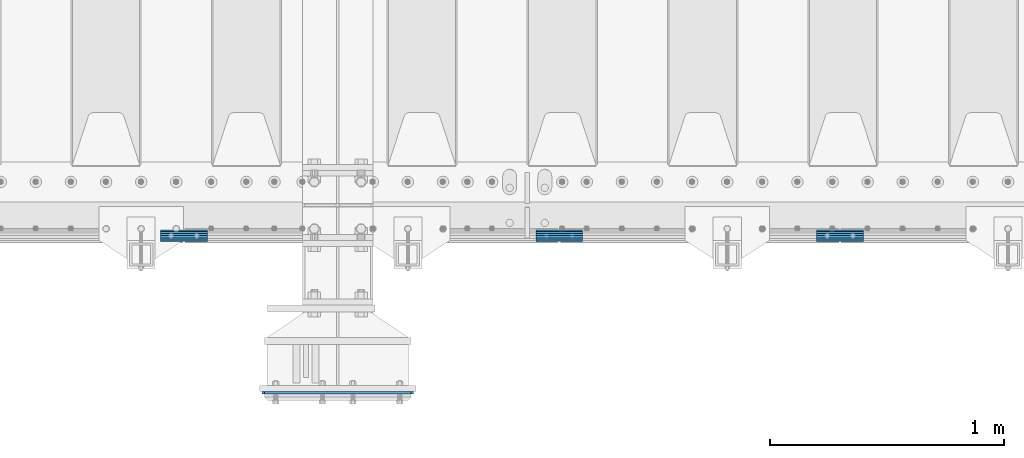
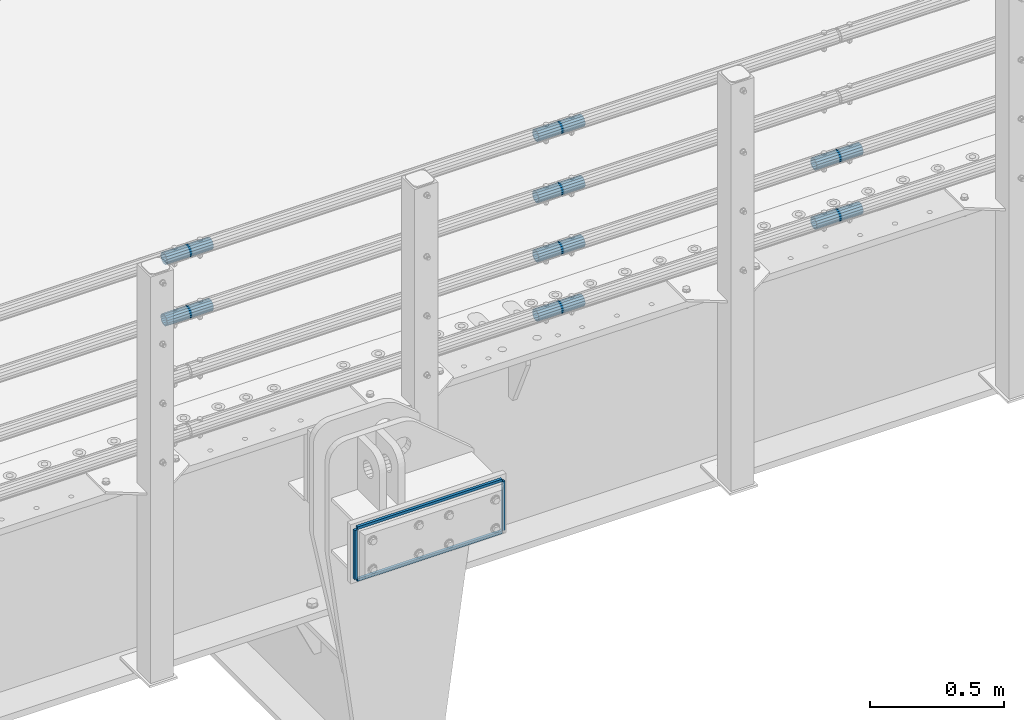
# One storey, part 126 of 219: 12 beams.
"""IFC2X3 building model written with IfcOpenShell, lengths in millimetres."""

from ifc_helpers import new_model, si_unit, frame, origin_with_axes, place, context, subcontext, project, spatial, faceted_brep, material, type_object, element, save


model = new_model("IFC2X3")

# Units and contexts
model_context = context("Model", 3, precision=1e-05, world=origin_with_axes())
body_context = subcontext(model_context, "Body", "Model", "MODEL_VIEW")
ifc_project = project(units=[si_unit("LENGTHUNIT", "METRE", prefix="MILLI"), si_unit("AREAUNIT", "SQUARE_METRE"), si_unit("VOLUMEUNIT", "CUBIC_METRE"), si_unit("MASSUNIT", "GRAM", prefix="KILO"), si_unit("TIMEUNIT", "SECOND"), si_unit("PLANEANGLEUNIT", "RADIAN"), si_unit("SOLIDANGLEUNIT", "STERADIAN"), si_unit("THERMODYNAMICTEMPERATUREUNIT", "DEGREE_CELSIUS"), si_unit("LUMINOUSINTENSITYUNIT", "LUMEN")], contexts=[model_context])

# Site, building, storey
site_placement = place(None, origin_with_axes())
site = spatial("IfcSite", under=ifc_project, at=site_placement, CompositionType="ELEMENT")
building_placement = place(site_placement, origin_with_axes())
building = spatial("IfcBuilding", under=site, at=building_placement, Name="Standard", CompositionType="ELEMENT")
storey_placement = place(building_placement, origin_with_axes())
storey = spatial("IfcBuildingStorey", under=building, at=storey_placement, Name="Undefined", CompositionType="ELEMENT", Elevation=0.0)

# Beams
ifc_material_1 = material(Name="STEEL/S355N")
beam_type_1 = type_object("IfcBeamType", PredefinedType="NOTDEFINED")
for number, where, z_axis, x_axis in (
    (1, (10071.5000000202, 23199.000000015, -12.5000182061987), (-1.0, 0.0, 0.0), (0.0, 0.0, -1.0)),
    (2, (10708.5000000219, 23199.0000000148, -12.5000182061987), (-1.0, 0.0, 0.0), (0.0, 0.0, -1.0)),
):
    element("IfcBeam", number, at=place(storey_placement, frame(where, z_axis=z_axis, x_axis=x_axis)), inside=storey, type_object=beam_type_1, material=ifc_material_1, context=body_context, shape_type="Brep", body=[
        faceted_brep([(0.0, 6.0, -6.0), (0.0, 6.0, 6.0), (225.0, 6.0, 6.0), (225.0, 6.0, -6.0), (0.0, -6.0, 6.0), (225.0, -6.0, 6.0), (0.0, -6.0, -6.0), (225.0, -6.0, -6.0)], [[[0, 1, 2, 3]], [[1, 4, 5, 2]], [[4, 6, 7, 5]], [[6, 0, 3, 7]], [[5, 7, 3, 2]], [[6, 4, 1, 0]]]),
    ])
for number, where, z_axis, x_axis in (
    (3, (10077.5000000202, 23199.000000015, -6.50001820619866), (0.0, 0.0, -1.0), (1.0, 0.0, 0.0)),
    (4, (10077.5000000202, 23199.000000015, -243.500018206199), (0.0, 0.0, -1.0), (1.0, 0.0, 0.0)),
):
    element("IfcBeam", number, at=place(storey_placement, frame(where, z_axis=z_axis, x_axis=x_axis)), inside=storey, type_object=beam_type_1, material=ifc_material_1, context=body_context, shape_type="Brep", body=[
        faceted_brep([(0.0, 6.0, -6.0), (0.0, 6.0, 6.0), (625.000000001684, 6.0, 6.0), (625.000000001684, 6.0, -6.0), (0.0, -6.0, 6.0), (625.000000001684, -6.0, 6.0), (0.0, -6.0, -6.0), (625.000000001684, -6.0, -6.0)], [[[0, 1, 2, 3]], [[1, 4, 5, 2]], [[4, 6, 7, 5]], [[6, 0, 3, 7]], [[5, 7, 3, 2]], [[6, 4, 1, 0]]]),
    ])
ifc_material_2 = material()
beam_type_2 = type_object("IfcBeamType", PredefinedType="NOTDEFINED")
beam_1_placement = place(storey_placement, frame((11236.9975029999, 23870.1500000004, 149.849999999747), z_axis=(0.0, 0.0, 1.0), x_axis=(1.0, 0.0, 0.0)))
element("IfcBeam", 5, at=beam_1_placement, inside=storey, type_object=beam_type_2, material=ifc_material_2, context=body_context, shape_type="Brep", body=[
    faceted_brep([(0.0, -21.9000000000015, 0.0), (0.0, -20.232961761998, 8.38076716879547), (200.0, -20.232961761998, 8.38076716879547), (200.0, -21.9000000000015, 0.0), (0.0, -15.4856385079838, 15.4856385079854), (200.0, -15.4856385079838, 15.4856385079854), (0.0, -8.38076716879732, 20.2329617619972), (200.0, -8.38076716879732, 20.2329617619972), (0.0, 0.0, 21.9), (200.0, 0.0, 21.9), (0.0, 8.38076716879732, 20.2329617619972), (200.0, 8.38076716879732, 20.2329617619972), (0.0, 15.4856385079838, 15.4856385079854), (200.0, 15.4856385079838, 15.4856385079854), (0.0, 20.232961761998, 8.38076716879547), (200.0, 20.232961761998, 8.38076716879547), (0.0, 21.9000000000015, 0.0), (200.0, 21.9000000000015, 0.0), (0.0, 20.232961761998, -8.38076716879547), (200.0, 20.232961761998, -8.38076716879547), (0.0, 15.4856385079838, -15.4856385079854), (200.0, 15.4856385079838, -15.4856385079854), (0.0, 8.38076716879732, -20.2329617619972), (200.0, 8.38076716879732, -20.2329617619972), (0.0, 0.0, -21.9), (200.0, 0.0, -21.9), (0.0, -8.38076716879732, -20.2329617619972), (200.0, -8.38076716879732, -20.2329617619972), (0.0, -15.4856385079838, -15.4856385079854), (200.0, -15.4856385079838, -15.4856385079854), (0.0, -20.232961761998, -8.38076716879547), (200.0, -20.232961761998, -8.38076716879547), (0.0, -25.5, 0.0), (0.0, -23.5589280790373, -9.7584275253098), (200.0, -23.5589280790373, -9.7584275253098), (200.0, -25.5, 0.0), (0.0, -18.0312229202536, -18.031222920257), (200.0, -18.0312229202536, -18.031222920257), (0.0, -9.75842752531025, -23.5589280790378), (200.0, -9.75842752531025, -23.5589280790378), (0.0, 0.0, -25.5), (200.0, 0.0, -25.5), (0.0, 9.75842752531025, -23.5589280790378), (200.0, 9.75842752531025, -23.5589280790378), (0.0, 18.0312229202536, -18.031222920257), (200.0, 18.0312229202536, -18.031222920257), (0.0, 23.5589280790373, -9.7584275253098), (200.0, 23.5589280790373, -9.7584275253098), (0.0, 25.5, 0.0), (200.0, 25.5, 0.0), (0.0, 23.5589280790373, 9.7584275253098), (200.0, 23.5589280790373, 9.7584275253098), (0.0, 18.0312229202536, 18.031222920257), (200.0, 18.0312229202536, 18.031222920257), (0.0, 9.75842752531025, 23.5589280790378), (200.0, 9.75842752531025, 23.5589280790378), (0.0, 0.0, 25.5), (200.0, 0.0, 25.5), (0.0, -9.75842752531025, 23.5589280790378), (200.0, -9.75842752531025, 23.5589280790378), (0.0, -18.0312229202536, 18.031222920257), (200.0, -18.0312229202536, 18.031222920257), (0.0, -23.5589280790373, 9.7584275253098), (200.0, -23.5589280790373, 9.7584275253098)], [[[0, 1, 2, 3]], [[1, 4, 5, 2]], [[4, 6, 7, 5]], [[6, 8, 9, 7]], [[8, 10, 11, 9]], [[10, 12, 13, 11]], [[12, 14, 15, 13]], [[14, 16, 17, 15]], [[16, 18, 19, 17]], [[18, 20, 21, 19]], [[20, 22, 23, 21]], [[22, 24, 25, 23]], [[24, 26, 27, 25]], [[26, 28, 29, 27]], [[28, 30, 31, 29]], [[30, 0, 3, 31]], [[32, 33, 34, 35]], [[33, 36, 37, 34]], [[36, 38, 39, 37]], [[38, 40, 41, 39]], [[40, 42, 43, 41]], [[42, 44, 45, 43]], [[44, 46, 47, 45]], [[46, 48, 49, 47]], [[48, 50, 51, 49]], [[50, 52, 53, 51]], [[52, 54, 55, 53]], [[54, 56, 57, 55]], [[56, 58, 59, 57]], [[58, 60, 61, 59]], [[60, 62, 63, 61]], [[62, 32, 35, 63]], [[37, 39, 41, 43, 45, 47, 49, 51, 53, 55, 57, 59, 61, 63, 35, 34], [5, 7, 9, 11, 13, 15, 17, 19, 21, 23, 25, 27, 29, 31, 3, 2]], [[62, 60, 58, 56, 54, 52, 50, 48, 46, 44, 42, 40, 38, 36, 33, 32], [30, 28, 26, 24, 22, 20, 18, 16, 14, 12, 10, 8, 6, 4, 1, 0]]]),
])
beam_2_placement = place(storey_placement, frame((11236.9975029999, 23870.1500000004, 420.149999999747), z_axis=(0.0, 0.0, 1.0), x_axis=(1.0, 0.0, 0.0)))
element("IfcBeam", 6, at=beam_2_placement, inside=storey, type_object=beam_type_2, material=ifc_material_2, context=body_context, shape_type="Brep", body=[
    faceted_brep([(0.0, -21.9000000000015, 0.0), (0.0, -20.232961761998, 8.38076716879547), (200.0, -20.232961761998, 8.38076716879547), (200.0, -21.9000000000015, 0.0), (0.0, -15.4856385079838, 15.4856385079854), (200.0, -15.4856385079838, 15.4856385079854), (0.0, -8.38076716879732, 20.2329617619972), (200.0, -8.38076716879732, 20.2329617619972), (0.0, 0.0, 21.9), (200.0, 0.0, 21.9), (0.0, 8.38076716879732, 20.2329617619972), (200.0, 8.38076716879732, 20.2329617619972), (0.0, 15.4856385079838, 15.4856385079854), (200.0, 15.4856385079838, 15.4856385079854), (0.0, 20.232961761998, 8.38076716879547), (200.0, 20.232961761998, 8.38076716879547), (0.0, 21.9000000000015, 0.0), (200.0, 21.9000000000015, 0.0), (0.0, 20.232961761998, -8.38076716879547), (200.0, 20.232961761998, -8.38076716879547), (0.0, 15.4856385079838, -15.4856385079854), (200.0, 15.4856385079838, -15.4856385079854), (0.0, 8.38076716879732, -20.2329617619972), (200.0, 8.38076716879732, -20.2329617619972), (0.0, 0.0, -21.9), (200.0, 0.0, -21.9), (0.0, -8.38076716879732, -20.2329617619972), (200.0, -8.38076716879732, -20.2329617619972), (0.0, -15.4856385079838, -15.4856385079854), (200.0, -15.4856385079838, -15.4856385079854), (0.0, -20.232961761998, -8.38076716879547), (200.0, -20.232961761998, -8.38076716879547), (0.0, -25.5, 0.0), (0.0, -23.5589280790373, -9.7584275253098), (200.0, -23.5589280790373, -9.7584275253098), (200.0, -25.5, 0.0), (0.0, -18.0312229202536, -18.031222920257), (200.0, -18.0312229202536, -18.031222920257), (0.0, -9.75842752531025, -23.5589280790378), (200.0, -9.75842752531025, -23.5589280790378), (0.0, 0.0, -25.5), (200.0, 0.0, -25.5), (0.0, 9.75842752531025, -23.5589280790378), (200.0, 9.75842752531025, -23.5589280790378), (0.0, 18.0312229202536, -18.031222920257), (200.0, 18.0312229202536, -18.031222920257), (0.0, 23.5589280790373, -9.7584275253098), (200.0, 23.5589280790373, -9.7584275253098), (0.0, 25.5, 0.0), (200.0, 25.5, 0.0), (0.0, 23.5589280790373, 9.7584275253098), (200.0, 23.5589280790373, 9.7584275253098), (0.0, 18.0312229202536, 18.031222920257), (200.0, 18.0312229202536, 18.031222920257), (0.0, 9.75842752531025, 23.5589280790378), (200.0, 9.75842752531025, 23.5589280790378), (0.0, 0.0, 25.5), (200.0, 0.0, 25.5), (0.0, -9.75842752531025, 23.5589280790378), (200.0, -9.75842752531025, 23.5589280790378), (0.0, -18.0312229202536, 18.031222920257), (200.0, -18.0312229202536, 18.031222920257), (0.0, -23.5589280790373, 9.7584275253098), (200.0, -23.5589280790373, 9.7584275253098)], [[[0, 1, 2, 3]], [[1, 4, 5, 2]], [[4, 6, 7, 5]], [[6, 8, 9, 7]], [[8, 10, 11, 9]], [[10, 12, 13, 11]], [[12, 14, 15, 13]], [[14, 16, 17, 15]], [[16, 18, 19, 17]], [[18, 20, 21, 19]], [[20, 22, 23, 21]], [[22, 24, 25, 23]], [[24, 26, 27, 25]], [[26, 28, 29, 27]], [[28, 30, 31, 29]], [[30, 0, 3, 31]], [[32, 33, 34, 35]], [[33, 36, 37, 34]], [[36, 38, 39, 37]], [[38, 40, 41, 39]], [[40, 42, 43, 41]], [[42, 44, 45, 43]], [[44, 46, 47, 45]], [[46, 48, 49, 47]], [[48, 50, 51, 49]], [[50, 52, 53, 51]], [[52, 54, 55, 53]], [[54, 56, 57, 55]], [[56, 58, 59, 57]], [[58, 60, 61, 59]], [[60, 62, 63, 61]], [[62, 32, 35, 63]], [[37, 39, 41, 43, 45, 47, 49, 51, 53, 55, 57, 59, 61, 63, 35, 34], [5, 7, 9, 11, 13, 15, 17, 19, 21, 23, 25, 27, 29, 31, 3, 2]], [[62, 60, 58, 56, 54, 52, 50, 48, 46, 44, 42, 40, 38, 36, 33, 32], [30, 28, 26, 24, 22, 20, 18, 16, 14, 12, 10, 8, 6, 4, 1, 0]]]),
])
beam_3_placement = place(storey_placement, frame((9632.99750299995, 23870.1500000004, 969.849999999747), z_axis=(0.0, 0.0, 1.0), x_axis=(1.0, 0.0, 0.0)))
element("IfcBeam", 7, at=beam_3_placement, inside=storey, type_object=beam_type_2, material=ifc_material_2, context=body_context, shape_type="Brep", body=[
    faceted_brep([(0.0, -21.9000000000015, 0.0), (0.0, -20.232961761998, 8.38076716879547), (200.0, -20.232961761998, 8.38076716879547), (200.0, -21.9000000000015, 0.0), (0.0, -15.4856385079838, 15.4856385079854), (200.0, -15.4856385079838, 15.4856385079854), (0.0, -8.38076716879732, 20.2329617619972), (200.0, -8.38076716879732, 20.2329617619972), (0.0, 0.0, 21.9), (200.0, 0.0, 21.9), (0.0, 8.38076716879732, 20.2329617619972), (200.0, 8.38076716879732, 20.2329617619972), (0.0, 15.4856385079838, 15.4856385079854), (200.0, 15.4856385079838, 15.4856385079854), (0.0, 20.232961761998, 8.38076716879547), (200.0, 20.232961761998, 8.38076716879547), (0.0, 21.9000000000015, 0.0), (200.0, 21.9000000000015, 0.0), (0.0, 20.232961761998, -8.38076716879547), (200.0, 20.232961761998, -8.38076716879547), (0.0, 15.4856385079838, -15.4856385079854), (200.0, 15.4856385079838, -15.4856385079854), (0.0, 8.38076716879732, -20.2329617619972), (200.0, 8.38076716879732, -20.2329617619972), (0.0, 0.0, -21.9), (200.0, 0.0, -21.9), (0.0, -8.38076716879732, -20.2329617619972), (200.0, -8.38076716879732, -20.2329617619972), (0.0, -15.4856385079838, -15.4856385079854), (200.0, -15.4856385079838, -15.4856385079854), (0.0, -20.232961761998, -8.38076716879547), (200.0, -20.232961761998, -8.38076716879547), (0.0, -25.5, 0.0), (0.0, -23.5589280790373, -9.7584275253098), (200.0, -23.5589280790373, -9.7584275253098), (200.0, -25.5, 0.0), (0.0, -18.0312229202536, -18.031222920257), (200.0, -18.0312229202536, -18.031222920257), (0.0, -9.75842752531025, -23.5589280790378), (200.0, -9.75842752531025, -23.5589280790378), (0.0, 0.0, -25.5), (200.0, 0.0, -25.5), (0.0, 9.75842752531025, -23.5589280790378), (200.0, 9.75842752531025, -23.5589280790378), (0.0, 18.0312229202536, -18.031222920257), (200.0, 18.0312229202536, -18.031222920257), (0.0, 23.5589280790373, -9.7584275253098), (200.0, 23.5589280790373, -9.7584275253098), (0.0, 25.5, 0.0), (200.0, 25.5, 0.0), (0.0, 23.5589280790373, 9.7584275253098), (200.0, 23.5589280790373, 9.7584275253098), (0.0, 18.0312229202536, 18.031222920257), (200.0, 18.0312229202536, 18.031222920257), (0.0, 9.75842752531025, 23.5589280790378), (200.0, 9.75842752531025, 23.5589280790378), (0.0, 0.0, 25.5), (200.0, 0.0, 25.5), (0.0, -9.75842752531025, 23.5589280790378), (200.0, -9.75842752531025, 23.5589280790378), (0.0, -18.0312229202536, 18.031222920257), (200.0, -18.0312229202536, 18.031222920257), (0.0, -23.5589280790373, 9.7584275253098), (200.0, -23.5589280790373, 9.7584275253098)], [[[0, 1, 2, 3]], [[1, 4, 5, 2]], [[4, 6, 7, 5]], [[6, 8, 9, 7]], [[8, 10, 11, 9]], [[10, 12, 13, 11]], [[12, 14, 15, 13]], [[14, 16, 17, 15]], [[16, 18, 19, 17]], [[18, 20, 21, 19]], [[20, 22, 23, 21]], [[22, 24, 25, 23]], [[24, 26, 27, 25]], [[26, 28, 29, 27]], [[28, 30, 31, 29]], [[30, 0, 3, 31]], [[32, 33, 34, 35]], [[33, 36, 37, 34]], [[36, 38, 39, 37]], [[38, 40, 41, 39]], [[40, 42, 43, 41]], [[42, 44, 45, 43]], [[44, 46, 47, 45]], [[46, 48, 49, 47]], [[48, 50, 51, 49]], [[50, 52, 53, 51]], [[52, 54, 55, 53]], [[54, 56, 57, 55]], [[56, 58, 59, 57]], [[58, 60, 61, 59]], [[60, 62, 63, 61]], [[62, 32, 35, 63]], [[37, 39, 41, 43, 45, 47, 49, 51, 53, 55, 57, 59, 61, 63, 35, 34], [5, 7, 9, 11, 13, 15, 17, 19, 21, 23, 25, 27, 29, 31, 3, 2]], [[62, 60, 58, 56, 54, 52, 50, 48, 46, 44, 42, 40, 38, 36, 33, 32], [30, 28, 26, 24, 22, 20, 18, 16, 14, 12, 10, 8, 6, 4, 1, 0]]]),
])
beam_4_placement = place(storey_placement, frame((11236.9975029999, 23870.1500000004, 969.849999999747), z_axis=(0.0, 0.0, 1.0), x_axis=(1.0, 0.0, 0.0)))
element("IfcBeam", 8, at=beam_4_placement, inside=storey, type_object=beam_type_2, material=ifc_material_2, context=body_context, shape_type="Brep", body=[
    faceted_brep([(0.0, -21.9000000000015, 0.0), (0.0, -20.232961761998, 8.38076716879547), (200.0, -20.232961761998, 8.38076716879547), (200.0, -21.9000000000015, 0.0), (0.0, -15.4856385079838, 15.4856385079854), (200.0, -15.4856385079838, 15.4856385079854), (0.0, -8.38076716879732, 20.2329617619972), (200.0, -8.38076716879732, 20.2329617619972), (0.0, 0.0, 21.9), (200.0, 0.0, 21.9), (0.0, 8.38076716879732, 20.2329617619972), (200.0, 8.38076716879732, 20.2329617619972), (0.0, 15.4856385079838, 15.4856385079854), (200.0, 15.4856385079838, 15.4856385079854), (0.0, 20.232961761998, 8.38076716879547), (200.0, 20.232961761998, 8.38076716879547), (0.0, 21.9000000000015, 0.0), (200.0, 21.9000000000015, 0.0), (0.0, 20.232961761998, -8.38076716879547), (200.0, 20.232961761998, -8.38076716879547), (0.0, 15.4856385079838, -15.4856385079854), (200.0, 15.4856385079838, -15.4856385079854), (0.0, 8.38076716879732, -20.2329617619972), (200.0, 8.38076716879732, -20.2329617619972), (0.0, 0.0, -21.9), (200.0, 0.0, -21.9), (0.0, -8.38076716879732, -20.2329617619972), (200.0, -8.38076716879732, -20.2329617619972), (0.0, -15.4856385079838, -15.4856385079854), (200.0, -15.4856385079838, -15.4856385079854), (0.0, -20.232961761998, -8.38076716879547), (200.0, -20.232961761998, -8.38076716879547), (0.0, -25.5, 0.0), (0.0, -23.5589280790373, -9.7584275253098), (200.0, -23.5589280790373, -9.7584275253098), (200.0, -25.5, 0.0), (0.0, -18.0312229202536, -18.031222920257), (200.0, -18.0312229202536, -18.031222920257), (0.0, -9.75842752531025, -23.5589280790378), (200.0, -9.75842752531025, -23.5589280790378), (0.0, 0.0, -25.5), (200.0, 0.0, -25.5), (0.0, 9.75842752531025, -23.5589280790378), (200.0, 9.75842752531025, -23.5589280790378), (0.0, 18.0312229202536, -18.031222920257), (200.0, 18.0312229202536, -18.031222920257), (0.0, 23.5589280790373, -9.7584275253098), (200.0, 23.5589280790373, -9.7584275253098), (0.0, 25.5, 0.0), (200.0, 25.5, 0.0), (0.0, 23.5589280790373, 9.7584275253098), (200.0, 23.5589280790373, 9.7584275253098), (0.0, 18.0312229202536, 18.031222920257), (200.0, 18.0312229202536, 18.031222920257), (0.0, 9.75842752531025, 23.5589280790378), (200.0, 9.75842752531025, 23.5589280790378), (0.0, 0.0, 25.5), (200.0, 0.0, 25.5), (0.0, -9.75842752531025, 23.5589280790378), (200.0, -9.75842752531025, 23.5589280790378), (0.0, -18.0312229202536, 18.031222920257), (200.0, -18.0312229202536, 18.031222920257), (0.0, -23.5589280790373, 9.7584275253098), (200.0, -23.5589280790373, 9.7584275253098)], [[[0, 1, 2, 3]], [[1, 4, 5, 2]], [[4, 6, 7, 5]], [[6, 8, 9, 7]], [[8, 10, 11, 9]], [[10, 12, 13, 11]], [[12, 14, 15, 13]], [[14, 16, 17, 15]], [[16, 18, 19, 17]], [[18, 20, 21, 19]], [[20, 22, 23, 21]], [[22, 24, 25, 23]], [[24, 26, 27, 25]], [[26, 28, 29, 27]], [[28, 30, 31, 29]], [[30, 0, 3, 31]], [[32, 33, 34, 35]], [[33, 36, 37, 34]], [[36, 38, 39, 37]], [[38, 40, 41, 39]], [[40, 42, 43, 41]], [[42, 44, 45, 43]], [[44, 46, 47, 45]], [[46, 48, 49, 47]], [[48, 50, 51, 49]], [[50, 52, 53, 51]], [[52, 54, 55, 53]], [[54, 56, 57, 55]], [[56, 58, 59, 57]], [[58, 60, 61, 59]], [[60, 62, 63, 61]], [[62, 32, 35, 63]], [[37, 39, 41, 43, 45, 47, 49, 51, 53, 55, 57, 59, 61, 63, 35, 34], [5, 7, 9, 11, 13, 15, 17, 19, 21, 23, 25, 27, 29, 31, 3, 2]], [[62, 60, 58, 56, 54, 52, 50, 48, 46, 44, 42, 40, 38, 36, 33, 32], [30, 28, 26, 24, 22, 20, 18, 16, 14, 12, 10, 8, 6, 4, 1, 0]]]),
])
beam_5_placement = place(storey_placement, frame((12436.9975029999, 23870.1500000004, 419.849999999747), z_axis=(0.0, 0.0, 1.0), x_axis=(1.0, 0.0, 0.0)))
element("IfcBeam", 9, at=beam_5_placement, inside=storey, type_object=beam_type_2, material=ifc_material_2, context=body_context, shape_type="Brep", body=[
    faceted_brep([(0.0, -21.9000000000015, 0.0), (0.0, -20.232961761998, 8.38076716879547), (200.0, -20.232961761998, 8.38076716879547), (200.0, -21.9000000000015, 0.0), (0.0, -15.4856385079838, 15.4856385079854), (200.0, -15.4856385079838, 15.4856385079854), (0.0, -8.38076716879732, 20.2329617619972), (200.0, -8.38076716879732, 20.2329617619972), (0.0, 0.0, 21.9), (200.0, 0.0, 21.9), (0.0, 8.38076716879732, 20.2329617619972), (200.0, 8.38076716879732, 20.2329617619972), (0.0, 15.4856385079838, 15.4856385079854), (200.0, 15.4856385079838, 15.4856385079854), (0.0, 20.232961761998, 8.38076716879547), (200.0, 20.232961761998, 8.38076716879547), (0.0, 21.9000000000015, 0.0), (200.0, 21.9000000000015, 0.0), (0.0, 20.232961761998, -8.38076716879547), (200.0, 20.232961761998, -8.38076716879547), (0.0, 15.4856385079838, -15.4856385079854), (200.0, 15.4856385079838, -15.4856385079854), (0.0, 8.38076716879732, -20.2329617619972), (200.0, 8.38076716879732, -20.2329617619972), (0.0, 0.0, -21.9), (200.0, 0.0, -21.9), (0.0, -8.38076716879732, -20.2329617619972), (200.0, -8.38076716879732, -20.2329617619972), (0.0, -15.4856385079838, -15.4856385079854), (200.0, -15.4856385079838, -15.4856385079854), (0.0, -20.232961761998, -8.38076716879547), (200.0, -20.232961761998, -8.38076716879547), (0.0, -25.5, 0.0), (0.0, -23.5589280790373, -9.7584275253098), (200.0, -23.5589280790373, -9.7584275253098), (200.0, -25.5, 0.0), (0.0, -18.0312229202536, -18.031222920257), (200.0, -18.0312229202536, -18.031222920257), (0.0, -9.75842752531025, -23.5589280790378), (200.0, -9.75842752531025, -23.5589280790378), (0.0, 0.0, -25.5), (200.0, 0.0, -25.5), (0.0, 9.75842752531025, -23.5589280790378), (200.0, 9.75842752531025, -23.5589280790378), (0.0, 18.0312229202536, -18.031222920257), (200.0, 18.0312229202536, -18.031222920257), (0.0, 23.5589280790373, -9.7584275253098), (200.0, 23.5589280790373, -9.7584275253098), (0.0, 25.5, 0.0), (200.0, 25.5, 0.0), (0.0, 23.5589280790373, 9.7584275253098), (200.0, 23.5589280790373, 9.7584275253098), (0.0, 18.0312229202536, 18.031222920257), (200.0, 18.0312229202536, 18.031222920257), (0.0, 9.75842752531025, 23.5589280790378), (200.0, 9.75842752531025, 23.5589280790378), (0.0, 0.0, 25.5), (200.0, 0.0, 25.5), (0.0, -9.75842752531025, 23.5589280790378), (200.0, -9.75842752531025, 23.5589280790378), (0.0, -18.0312229202536, 18.031222920257), (200.0, -18.0312229202536, 18.031222920257), (0.0, -23.5589280790373, 9.7584275253098), (200.0, -23.5589280790373, 9.7584275253098)], [[[0, 1, 2, 3]], [[1, 4, 5, 2]], [[4, 6, 7, 5]], [[6, 8, 9, 7]], [[8, 10, 11, 9]], [[10, 12, 13, 11]], [[12, 14, 15, 13]], [[14, 16, 17, 15]], [[16, 18, 19, 17]], [[18, 20, 21, 19]], [[20, 22, 23, 21]], [[22, 24, 25, 23]], [[24, 26, 27, 25]], [[26, 28, 29, 27]], [[28, 30, 31, 29]], [[30, 0, 3, 31]], [[32, 33, 34, 35]], [[33, 36, 37, 34]], [[36, 38, 39, 37]], [[38, 40, 41, 39]], [[40, 42, 43, 41]], [[42, 44, 45, 43]], [[44, 46, 47, 45]], [[46, 48, 49, 47]], [[48, 50, 51, 49]], [[50, 52, 53, 51]], [[52, 54, 55, 53]], [[54, 56, 57, 55]], [[56, 58, 59, 57]], [[58, 60, 61, 59]], [[60, 62, 63, 61]], [[62, 32, 35, 63]], [[37, 39, 41, 43, 45, 47, 49, 51, 53, 55, 57, 59, 61, 63, 35, 34], [5, 7, 9, 11, 13, 15, 17, 19, 21, 23, 25, 27, 29, 31, 3, 2]], [[62, 60, 58, 56, 54, 52, 50, 48, 46, 44, 42, 40, 38, 36, 33, 32], [30, 28, 26, 24, 22, 20, 18, 16, 14, 12, 10, 8, 6, 4, 1, 0]]]),
])
beam_6_placement = place(storey_placement, frame((12436.9975029999, 23870.1500000004, 149.849999999747), z_axis=(0.0, 0.0, 1.0), x_axis=(1.0, 0.0, 0.0)))
element("IfcBeam", 10, at=beam_6_placement, inside=storey, type_object=beam_type_2, material=ifc_material_2, context=body_context, shape_type="Brep", body=[
    faceted_brep([(0.0, -21.9000000000015, 0.0), (0.0, -20.232961761998, 8.38076716879547), (200.0, -20.232961761998, 8.38076716879547), (200.0, -21.9000000000015, 0.0), (0.0, -15.4856385079838, 15.4856385079854), (200.0, -15.4856385079838, 15.4856385079854), (0.0, -8.38076716879732, 20.2329617619972), (200.0, -8.38076716879732, 20.2329617619972), (0.0, 0.0, 21.9), (200.0, 0.0, 21.9), (0.0, 8.38076716879732, 20.2329617619972), (200.0, 8.38076716879732, 20.2329617619972), (0.0, 15.4856385079838, 15.4856385079854), (200.0, 15.4856385079838, 15.4856385079854), (0.0, 20.232961761998, 8.38076716879547), (200.0, 20.232961761998, 8.38076716879547), (0.0, 21.9000000000015, 0.0), (200.0, 21.9000000000015, 0.0), (0.0, 20.232961761998, -8.38076716879547), (200.0, 20.232961761998, -8.38076716879547), (0.0, 15.4856385079838, -15.4856385079854), (200.0, 15.4856385079838, -15.4856385079854), (0.0, 8.38076716879732, -20.2329617619972), (200.0, 8.38076716879732, -20.2329617619972), (0.0, 0.0, -21.9), (200.0, 0.0, -21.9), (0.0, -8.38076716879732, -20.2329617619972), (200.0, -8.38076716879732, -20.2329617619972), (0.0, -15.4856385079838, -15.4856385079854), (200.0, -15.4856385079838, -15.4856385079854), (0.0, -20.232961761998, -8.38076716879547), (200.0, -20.232961761998, -8.38076716879547), (0.0, -25.5, 0.0), (0.0, -23.5589280790373, -9.7584275253098), (200.0, -23.5589280790373, -9.7584275253098), (200.0, -25.5, 0.0), (0.0, -18.0312229202536, -18.031222920257), (200.0, -18.0312229202536, -18.031222920257), (0.0, -9.75842752531025, -23.5589280790378), (200.0, -9.75842752531025, -23.5589280790378), (0.0, 0.0, -25.5), (200.0, 0.0, -25.5), (0.0, 9.75842752531025, -23.5589280790378), (200.0, 9.75842752531025, -23.5589280790378), (0.0, 18.0312229202536, -18.031222920257), (200.0, 18.0312229202536, -18.031222920257), (0.0, 23.5589280790373, -9.7584275253098), (200.0, 23.5589280790373, -9.7584275253098), (0.0, 25.5, 0.0), (200.0, 25.5, 0.0), (0.0, 23.5589280790373, 9.7584275253098), (200.0, 23.5589280790373, 9.7584275253098), (0.0, 18.0312229202536, 18.031222920257), (200.0, 18.0312229202536, 18.031222920257), (0.0, 9.75842752531025, 23.5589280790378), (200.0, 9.75842752531025, 23.5589280790378), (0.0, 0.0, 25.5), (200.0, 0.0, 25.5), (0.0, -9.75842752531025, 23.5589280790378), (200.0, -9.75842752531025, 23.5589280790378), (0.0, -18.0312229202536, 18.031222920257), (200.0, -18.0312229202536, 18.031222920257), (0.0, -23.5589280790373, 9.7584275253098), (200.0, -23.5589280790373, 9.7584275253098)], [[[0, 1, 2, 3]], [[1, 4, 5, 2]], [[4, 6, 7, 5]], [[6, 8, 9, 7]], [[8, 10, 11, 9]], [[10, 12, 13, 11]], [[12, 14, 15, 13]], [[14, 16, 17, 15]], [[16, 18, 19, 17]], [[18, 20, 21, 19]], [[20, 22, 23, 21]], [[22, 24, 25, 23]], [[24, 26, 27, 25]], [[26, 28, 29, 27]], [[28, 30, 31, 29]], [[30, 0, 3, 31]], [[32, 33, 34, 35]], [[33, 36, 37, 34]], [[36, 38, 39, 37]], [[38, 40, 41, 39]], [[40, 42, 43, 41]], [[42, 44, 45, 43]], [[44, 46, 47, 45]], [[46, 48, 49, 47]], [[48, 50, 51, 49]], [[50, 52, 53, 51]], [[52, 54, 55, 53]], [[54, 56, 57, 55]], [[56, 58, 59, 57]], [[58, 60, 61, 59]], [[60, 62, 63, 61]], [[62, 32, 35, 63]], [[37, 39, 41, 43, 45, 47, 49, 51, 53, 55, 57, 59, 61, 63, 35, 34], [5, 7, 9, 11, 13, 15, 17, 19, 21, 23, 25, 27, 29, 31, 3, 2]], [[62, 60, 58, 56, 54, 52, 50, 48, 46, 44, 42, 40, 38, 36, 33, 32], [30, 28, 26, 24, 22, 20, 18, 16, 14, 12, 10, 8, 6, 4, 1, 0]]]),
])
beam_7_placement = place(storey_placement, frame((9632.99750299995, 23870.1500000004, 689.849999999747), z_axis=(0.0, 0.0, 1.0), x_axis=(1.0, 0.0, 0.0)))
element("IfcBeam", 11, at=beam_7_placement, inside=storey, type_object=beam_type_2, material=ifc_material_2, context=body_context, shape_type="Brep", body=[
    faceted_brep([(0.0, -21.9000000000015, 0.0), (0.0, -20.232961761998, 8.38076716879547), (200.0, -20.232961761998, 8.38076716879547), (200.0, -21.9000000000015, 0.0), (0.0, -15.4856385079838, 15.4856385079854), (200.0, -15.4856385079838, 15.4856385079854), (0.0, -8.38076716879732, 20.2329617619972), (200.0, -8.38076716879732, 20.2329617619972), (0.0, 0.0, 21.9), (200.0, 0.0, 21.9), (0.0, 8.38076716879732, 20.2329617619972), (200.0, 8.38076716879732, 20.2329617619972), (0.0, 15.4856385079838, 15.4856385079854), (200.0, 15.4856385079838, 15.4856385079854), (0.0, 20.232961761998, 8.38076716879547), (200.0, 20.232961761998, 8.38076716879547), (0.0, 21.9000000000015, 0.0), (200.0, 21.9000000000015, 0.0), (0.0, 20.232961761998, -8.38076716879547), (200.0, 20.232961761998, -8.38076716879547), (0.0, 15.4856385079838, -15.4856385079854), (200.0, 15.4856385079838, -15.4856385079854), (0.0, 8.38076716879732, -20.2329617619972), (200.0, 8.38076716879732, -20.2329617619972), (0.0, 0.0, -21.9), (200.0, 0.0, -21.9), (0.0, -8.38076716879732, -20.2329617619972), (200.0, -8.38076716879732, -20.2329617619972), (0.0, -15.4856385079838, -15.4856385079854), (200.0, -15.4856385079838, -15.4856385079854), (0.0, -20.232961761998, -8.38076716879547), (200.0, -20.232961761998, -8.38076716879547), (0.0, -25.5, 0.0), (0.0, -23.5589280790373, -9.7584275253098), (200.0, -23.5589280790373, -9.7584275253098), (200.0, -25.5, 0.0), (0.0, -18.0312229202536, -18.031222920257), (200.0, -18.0312229202536, -18.031222920257), (0.0, -9.75842752531025, -23.5589280790378), (200.0, -9.75842752531025, -23.5589280790378), (0.0, 0.0, -25.5), (200.0, 0.0, -25.5), (0.0, 9.75842752531025, -23.5589280790378), (200.0, 9.75842752531025, -23.5589280790378), (0.0, 18.0312229202536, -18.031222920257), (200.0, 18.0312229202536, -18.031222920257), (0.0, 23.5589280790373, -9.7584275253098), (200.0, 23.5589280790373, -9.7584275253098), (0.0, 25.5, 0.0), (200.0, 25.5, 0.0), (0.0, 23.5589280790373, 9.7584275253098), (200.0, 23.5589280790373, 9.7584275253098), (0.0, 18.0312229202536, 18.031222920257), (200.0, 18.0312229202536, 18.031222920257), (0.0, 9.75842752531025, 23.5589280790378), (200.0, 9.75842752531025, 23.5589280790378), (0.0, 0.0, 25.5), (200.0, 0.0, 25.5), (0.0, -9.75842752531025, 23.5589280790378), (200.0, -9.75842752531025, 23.5589280790378), (0.0, -18.0312229202536, 18.031222920257), (200.0, -18.0312229202536, 18.031222920257), (0.0, -23.5589280790373, 9.7584275253098), (200.0, -23.5589280790373, 9.7584275253098)], [[[0, 1, 2, 3]], [[1, 4, 5, 2]], [[4, 6, 7, 5]], [[6, 8, 9, 7]], [[8, 10, 11, 9]], [[10, 12, 13, 11]], [[12, 14, 15, 13]], [[14, 16, 17, 15]], [[16, 18, 19, 17]], [[18, 20, 21, 19]], [[20, 22, 23, 21]], [[22, 24, 25, 23]], [[24, 26, 27, 25]], [[26, 28, 29, 27]], [[28, 30, 31, 29]], [[30, 0, 3, 31]], [[32, 33, 34, 35]], [[33, 36, 37, 34]], [[36, 38, 39, 37]], [[38, 40, 41, 39]], [[40, 42, 43, 41]], [[42, 44, 45, 43]], [[44, 46, 47, 45]], [[46, 48, 49, 47]], [[48, 50, 51, 49]], [[50, 52, 53, 51]], [[52, 54, 55, 53]], [[54, 56, 57, 55]], [[56, 58, 59, 57]], [[58, 60, 61, 59]], [[60, 62, 63, 61]], [[62, 32, 35, 63]], [[37, 39, 41, 43, 45, 47, 49, 51, 53, 55, 57, 59, 61, 63, 35, 34], [5, 7, 9, 11, 13, 15, 17, 19, 21, 23, 25, 27, 29, 31, 3, 2]], [[62, 60, 58, 56, 54, 52, 50, 48, 46, 44, 42, 40, 38, 36, 33, 32], [30, 28, 26, 24, 22, 20, 18, 16, 14, 12, 10, 8, 6, 4, 1, 0]]]),
])
beam_8_placement = place(storey_placement, frame((11236.9975029999, 23870.1500000004, 689.849999999747), z_axis=(0.0, 0.0, 1.0), x_axis=(1.0, 0.0, 0.0)))
element("IfcBeam", 12, at=beam_8_placement, inside=storey, type_object=beam_type_2, material=ifc_material_2, context=body_context, shape_type="Brep", body=[
    faceted_brep([(0.0, -21.9000000000015, 0.0), (0.0, -20.232961761998, 8.38076716879547), (200.0, -20.232961761998, 8.38076716879547), (200.0, -21.9000000000015, 0.0), (0.0, -15.4856385079838, 15.4856385079854), (200.0, -15.4856385079838, 15.4856385079854), (0.0, -8.38076716879732, 20.2329617619972), (200.0, -8.38076716879732, 20.2329617619972), (0.0, 0.0, 21.9), (200.0, 0.0, 21.9), (0.0, 8.38076716879732, 20.2329617619972), (200.0, 8.38076716879732, 20.2329617619972), (0.0, 15.4856385079838, 15.4856385079854), (200.0, 15.4856385079838, 15.4856385079854), (0.0, 20.232961761998, 8.38076716879547), (200.0, 20.232961761998, 8.38076716879547), (0.0, 21.9000000000015, 0.0), (200.0, 21.9000000000015, 0.0), (0.0, 20.232961761998, -8.38076716879547), (200.0, 20.232961761998, -8.38076716879547), (0.0, 15.4856385079838, -15.4856385079854), (200.0, 15.4856385079838, -15.4856385079854), (0.0, 8.38076716879732, -20.2329617619972), (200.0, 8.38076716879732, -20.2329617619972), (0.0, 0.0, -21.9), (200.0, 0.0, -21.9), (0.0, -8.38076716879732, -20.2329617619972), (200.0, -8.38076716879732, -20.2329617619972), (0.0, -15.4856385079838, -15.4856385079854), (200.0, -15.4856385079838, -15.4856385079854), (0.0, -20.232961761998, -8.38076716879547), (200.0, -20.232961761998, -8.38076716879547), (0.0, -25.5, 0.0), (0.0, -23.5589280790373, -9.7584275253098), (200.0, -23.5589280790373, -9.7584275253098), (200.0, -25.5, 0.0), (0.0, -18.0312229202536, -18.031222920257), (200.0, -18.0312229202536, -18.031222920257), (0.0, -9.75842752531025, -23.5589280790378), (200.0, -9.75842752531025, -23.5589280790378), (0.0, 0.0, -25.5), (200.0, 0.0, -25.5), (0.0, 9.75842752531025, -23.5589280790378), (200.0, 9.75842752531025, -23.5589280790378), (0.0, 18.0312229202536, -18.031222920257), (200.0, 18.0312229202536, -18.031222920257), (0.0, 23.5589280790373, -9.7584275253098), (200.0, 23.5589280790373, -9.7584275253098), (0.0, 25.5, 0.0), (200.0, 25.5, 0.0), (0.0, 23.5589280790373, 9.7584275253098), (200.0, 23.5589280790373, 9.7584275253098), (0.0, 18.0312229202536, 18.031222920257), (200.0, 18.0312229202536, 18.031222920257), (0.0, 9.75842752531025, 23.5589280790378), (200.0, 9.75842752531025, 23.5589280790378), (0.0, 0.0, 25.5), (200.0, 0.0, 25.5), (0.0, -9.75842752531025, 23.5589280790378), (200.0, -9.75842752531025, 23.5589280790378), (0.0, -18.0312229202536, 18.031222920257), (200.0, -18.0312229202536, 18.031222920257), (0.0, -23.5589280790373, 9.7584275253098), (200.0, -23.5589280790373, 9.7584275253098)], [[[0, 1, 2, 3]], [[1, 4, 5, 2]], [[4, 6, 7, 5]], [[6, 8, 9, 7]], [[8, 10, 11, 9]], [[10, 12, 13, 11]], [[12, 14, 15, 13]], [[14, 16, 17, 15]], [[16, 18, 19, 17]], [[18, 20, 21, 19]], [[20, 22, 23, 21]], [[22, 24, 25, 23]], [[24, 26, 27, 25]], [[26, 28, 29, 27]], [[28, 30, 31, 29]], [[30, 0, 3, 31]], [[32, 33, 34, 35]], [[33, 36, 37, 34]], [[36, 38, 39, 37]], [[38, 40, 41, 39]], [[40, 42, 43, 41]], [[42, 44, 45, 43]], [[44, 46, 47, 45]], [[46, 48, 49, 47]], [[48, 50, 51, 49]], [[50, 52, 53, 51]], [[52, 54, 55, 53]], [[54, 56, 57, 55]], [[56, 58, 59, 57]], [[58, 60, 61, 59]], [[60, 62, 63, 61]], [[62, 32, 35, 63]], [[37, 39, 41, 43, 45, 47, 49, 51, 53, 55, 57, 59, 61, 63, 35, 34], [5, 7, 9, 11, 13, 15, 17, 19, 21, 23, 25, 27, 29, 31, 3, 2]], [[62, 60, 58, 56, 54, 52, 50, 48, 46, 44, 42, 40, 38, 36, 33, 32], [30, 28, 26, 24, 22, 20, 18, 16, 14, 12, 10, 8, 6, 4, 1, 0]]]),
])

save(model, "model.ifc")
